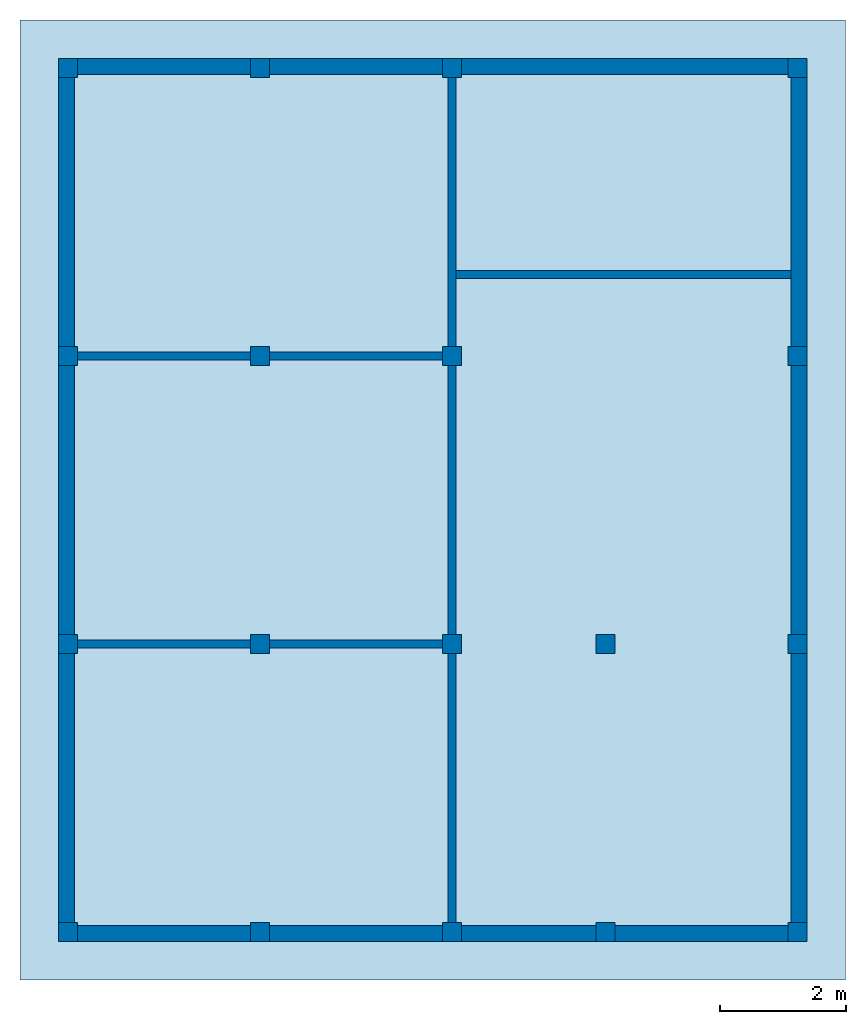
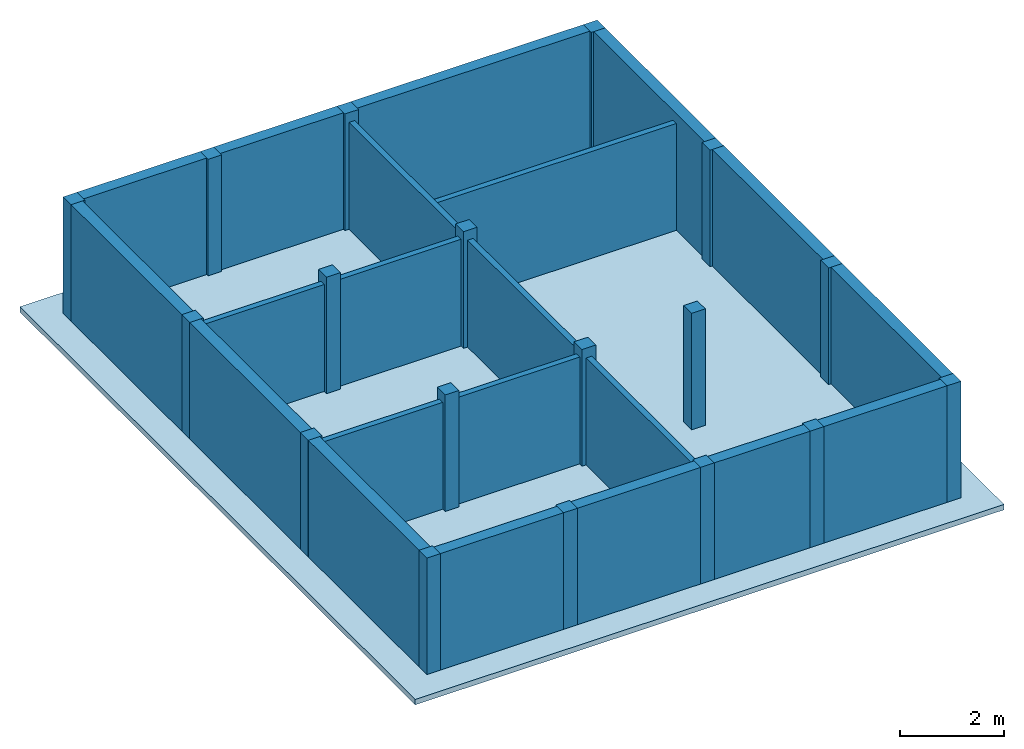
# One storey: 18 columns, 10 walls, 1 slab.
"""IFC2X3 building model written with IfcOpenShell, lengths in feet."""

from ifc_helpers import new_model, entity, si_unit, converted_unit, derived_unit, direction, frame, frame_2d, origin, origin_2d_with_axis, place, context, subcontext, project, spatial, rectangle, extrude, source, transform, mapped, material, layer, layer_set, layer_usage, type_object, type_shapes, element, save


model = new_model("IFC2X3")

# Units and contexts
model_context = context("Model", 3, precision=0.0001, world=origin(), true_north=direction((6.123031769111886e-17, 1.0)))
body_context = subcontext(model_context, "Body", "Model", "MODEL_VIEW")
ifc_project = project(units=[converted_unit("LENGTHUNIT", "FOOT", entity("IfcLengthMeasure", 0.3048), si_unit("LENGTHUNIT", "METRE"), dimensions=[1, 0, 0, 0, 0, 0, 0]), converted_unit("AREAUNIT", "SQUARE FOOT", entity("IfcAreaMeasure", 0.09290304), si_unit("AREAUNIT", "SQUARE_METRE"), dimensions=[2, 0, 0, 0, 0, 0, 0]), converted_unit("VOLUMEUNIT", "CUBIC FOOT", entity("IfcVolumeMeasure", 0.028316846592000004), si_unit("VOLUMEUNIT", "CUBIC_METRE"), dimensions=[3, 0, 0, 0, 0, 0, 0]), converted_unit("PLANEANGLEUNIT", "DEGREE", entity("IfcPlaneAngleMeasure", 0.017453292519943278), si_unit("PLANEANGLEUNIT", "RADIAN"), dimensions=[0, 0, 0, 0, 0, 0, 0]), si_unit("MASSUNIT", "GRAM", prefix="KILO"), derived_unit("MASSDENSITYUNIT", [(si_unit("MASSUNIT", "GRAM", prefix="KILO"), 1), (si_unit("LENGTHUNIT", "METRE"), -3)]), derived_unit("IONCONCENTRATIONUNIT", [(si_unit("MASSUNIT", "GRAM", prefix="KILO"), 1), (si_unit("LENGTHUNIT", "METRE"), -3)]), derived_unit("MOMENTOFINERTIAUNIT", [(si_unit("LENGTHUNIT", "METRE"), 4)]), si_unit("TIMEUNIT", "SECOND"), si_unit("FREQUENCYUNIT", "HERTZ"), si_unit("THERMODYNAMICTEMPERATUREUNIT", "DEGREE_CELSIUS"), derived_unit("THERMALTRANSMITTANCEUNIT", [(si_unit("MASSUNIT", "GRAM", prefix="KILO"), 1), (si_unit("THERMODYNAMICTEMPERATUREUNIT", "KELVIN"), -1), (si_unit("TIMEUNIT", "SECOND"), -3)]), derived_unit("THERMALCONDUCTANCEUNIT", [(si_unit("MASSUNIT", "GRAM", prefix="KILO"), 1), (si_unit("THERMODYNAMICTEMPERATUREUNIT", "KELVIN"), -1), (si_unit("TIMEUNIT", "SECOND"), -3), (si_unit("LENGTHUNIT", "METRE"), 1)]), derived_unit("VOLUMETRICFLOWRATEUNIT", [(si_unit("LENGTHUNIT", "METRE"), 3), (si_unit("TIMEUNIT", "SECOND"), -1)]), derived_unit("MASSFLOWRATEUNIT", [(si_unit("MASSUNIT", "GRAM", prefix="KILO"), 1), (si_unit("TIMEUNIT", "SECOND"), -1)]), derived_unit("ROTATIONALFREQUENCYUNIT", [(si_unit("TIMEUNIT", "SECOND"), -1)]), si_unit("ELECTRICCURRENTUNIT", "AMPERE"), si_unit("ELECTRICVOLTAGEUNIT", "VOLT"), si_unit("POWERUNIT", "WATT"), converted_unit("FORCEUNIT", "KIP", entity("IfcForceMeasure", 2.088543423315013e-05), si_unit("FORCEUNIT", "NEWTON"), dimensions=[1, 1, -2, 0, 0, 0, 0]), si_unit("ILLUMINANCEUNIT", "LUX"), si_unit("LUMINOUSFLUXUNIT", "LUMEN"), si_unit("LUMINOUSINTENSITYUNIT", "CANDELA"), si_unit("ENERGYUNIT", "JOULE"), derived_unit("USERDEFINED", [(si_unit("MASSUNIT", "GRAM", prefix="KILO"), -1), (si_unit("LENGTHUNIT", "METRE"), -2), (si_unit("TIMEUNIT", "SECOND"), 3), (si_unit("LUMINOUSFLUXUNIT", "LUMEN"), 1)]), derived_unit("USERDEFINED", [(si_unit("MASSUNIT", "GRAM", prefix="KILO"), 1), (si_unit("TIMEUNIT", "SECOND"), -3), (si_unit("LENGTHUNIT", "METRE"), 3), (si_unit("ELECTRICCURRENTUNIT", "AMPERE"), -2)]), derived_unit("SOUNDPOWERUNIT", [(si_unit("MASSUNIT", "GRAM", prefix="KILO"), 1), (si_unit("TIMEUNIT", "SECOND"), -3), (si_unit("LENGTHUNIT", "METRE"), 2)]), derived_unit("SOUNDPRESSUREUNIT", [(si_unit("MASSUNIT", "GRAM", prefix="KILO"), 1), (si_unit("LENGTHUNIT", "METRE"), -1), (si_unit("TIMEUNIT", "SECOND"), -2)]), derived_unit("LINEARVELOCITYUNIT", [(si_unit("LENGTHUNIT", "METRE"), 1), (si_unit("TIMEUNIT", "SECOND"), -1)]), si_unit("PRESSUREUNIT", "PASCAL"), derived_unit("USERDEFINED", [(si_unit("MASSUNIT", "GRAM", prefix="KILO"), 1), (si_unit("LENGTHUNIT", "METRE"), -2), (si_unit("TIMEUNIT", "SECOND"), -2)]), derived_unit("LINEARFORCEUNIT", [(si_unit("MASSUNIT", "GRAM", prefix="KILO"), 1), (si_unit("TIMEUNIT", "SECOND"), -2)]), derived_unit("PLANARFORCEUNIT", [(si_unit("MASSUNIT", "GRAM", prefix="KILO"), 1), (si_unit("LENGTHUNIT", "METRE"), -1), (si_unit("TIMEUNIT", "SECOND"), -2)]), derived_unit("SPECIFICHEATCAPACITYUNIT", [(si_unit("THERMODYNAMICTEMPERATUREUNIT", "KELVIN"), -1), (si_unit("LENGTHUNIT", "METRE"), 2), (si_unit("TIMEUNIT", "SECOND"), -2)]), derived_unit("HEATFLUXDENSITYUNIT", [(si_unit("MASSUNIT", "GRAM", prefix="KILO"), 1), (si_unit("TIMEUNIT", "SECOND"), -3)]), derived_unit("HEATINGVALUEUNIT", [(si_unit("LENGTHUNIT", "METRE"), 2), (si_unit("TIMEUNIT", "SECOND"), -2)]), derived_unit("VAPORPERMEABILITYUNIT", [(si_unit("LENGTHUNIT", "METRE"), -1), (si_unit("TIMEUNIT", "SECOND"), 1)]), derived_unit("DYNAMICVISCOSITYUNIT", [(si_unit("MASSUNIT", "GRAM", prefix="KILO"), 1), (si_unit("TIMEUNIT", "SECOND"), -1), (si_unit("LENGTHUNIT", "METRE"), -1)]), derived_unit("THERMALEXPANSIONCOEFFICIENTUNIT", [(si_unit("THERMODYNAMICTEMPERATUREUNIT", "KELVIN"), -1)]), derived_unit("MODULUSOFELASTICITYUNIT", [(si_unit("MASSUNIT", "GRAM", prefix="KILO"), 1), (si_unit("LENGTHUNIT", "METRE"), -1), (si_unit("TIMEUNIT", "SECOND"), -2)]), derived_unit("ISOTHERMALMOISTURECAPACITYUNIT", [(si_unit("LENGTHUNIT", "METRE"), 3), (si_unit("MASSUNIT", "GRAM", prefix="KILO"), -1)]), derived_unit("MOISTUREDIFFUSIVITYUNIT", [(si_unit("TIMEUNIT", "SECOND"), -1), (si_unit("LENGTHUNIT", "METRE"), 2)]), derived_unit("MASSPERLENGTHUNIT", [(si_unit("MASSUNIT", "GRAM", prefix="KILO"), 1), (si_unit("LENGTHUNIT", "METRE"), -1)]), derived_unit("THERMALRESISTANCEUNIT", [(si_unit("MASSUNIT", "GRAM", prefix="KILO"), -1), (si_unit("TIMEUNIT", "SECOND"), 3), (si_unit("THERMODYNAMICTEMPERATUREUNIT", "KELVIN"), 1)]), derived_unit("ACCELERATIONUNIT", [(si_unit("LENGTHUNIT", "METRE"), 1), (si_unit("TIMEUNIT", "SECOND"), -2)]), derived_unit("ANGULARVELOCITYUNIT", [(si_unit("TIMEUNIT", "SECOND"), -1), (si_unit("PLANEANGLEUNIT", "RADIAN"), 1)]), derived_unit("LINEARSTIFFNESSUNIT", [(si_unit("MASSUNIT", "GRAM", prefix="KILO"), 1), (si_unit("TIMEUNIT", "SECOND"), -2)]), derived_unit("WARPINGCONSTANTUNIT", [(si_unit("LENGTHUNIT", "METRE"), 6)]), derived_unit("LINEARMOMENTUNIT", [(si_unit("MASSUNIT", "GRAM", prefix="KILO"), 1), (si_unit("LENGTHUNIT", "METRE"), 1), (si_unit("TIMEUNIT", "SECOND"), -2)]), derived_unit("TORQUEUNIT", [(si_unit("MASSUNIT", "GRAM", prefix="KILO"), 1), (si_unit("LENGTHUNIT", "METRE"), 2), (si_unit("TIMEUNIT", "SECOND"), -2)])], contexts=[model_context])

# Site, building, storey
site_placement = place(None, origin())
site = spatial("IfcSite", under=ifc_project, at=site_placement, CompositionType="ELEMENT")
building_placement = place(site_placement, origin())
building = spatial("IfcBuilding", under=site, at=building_placement, CompositionType="ELEMENT")
storey_placement = place(building_placement, frame((0.0, 0.0, 18.833333333333574)))
storey = spatial("IfcBuildingStorey", under=building, at=storey_placement, Name="Second Floor", CompositionType="ELEMENT", Elevation=18.833333333333574)

# Columns
ifc_material_1 = material(Name="Concrete, Cast-in-Place gray")
column_type = type_object("IfcColumnType", PredefinedType="COLUMN", material=ifc_material_1)
shared_shape = source(origin(), body_context, "Body", "SweptSolid", [
    extrude(rectangle(XDim=0.9999999999999999, YDim=0.9999999999999999, at=origin_2d_with_axis()), frame((0.0, 0.0, 18.833333333333574), z_axis=(0.0, 0.0, 1.0), x_axis=(-1.0, 0.0, 0.0)), (0.0, 0.0, 1.0), 9.00000000000162),
])
type_shapes(column_type, [shared_shape])
for number, where in (
    (1, (9.874478019162162, -49.84124484724893, -18.833333333333574)),
    (2, (29.874478019162154, -49.841244847248994, -18.833333333333574)),
    (3, (37.87447801916216, -49.84124484724902, -18.833333333333574)),
    (4, (47.87447801916217, -49.84124484724906, -18.833333333333574)),
    (5, (19.874478019162158, -49.841244847248966, -18.833333333333574)),
    (6, (9.874478019162186, -34.84124484724893, -18.833333333333574)),
    (7, (29.87447801916219, -34.841244847248994, -18.833333333333574)),
    (8, (37.87447801916219, -34.84124484724902, -18.833333333333574)),
    (9, (47.87447801916219, -34.84124484724906, -18.833333333333574)),
    (10, (19.874478019162183, -34.841244847248966, -18.833333333333574)),
    (11, (9.874478019162211, -19.841244847248934, -18.833333333333574)),
    (12, (29.87447801916221, -19.841244847248998, -18.833333333333574)),
    (13, (47.87447801916221, -19.841244847249058, -18.833333333333574)),
    (14, (19.874478019162204, -19.841244847248966, -18.833333333333574)),
    (15, (9.874478019162234, -4.841244847248884, -18.833333333333574)),
    (16, (29.874478019162233, -4.841244847248948, -18.833333333333574)),
    (17, (47.87447801916224, -4.841244847249006, -18.833333333333574)),
    (18, (19.87447801916223, -4.841244847248915, -18.833333333333574)),
):
    element("IfcColumn", number, at=place(storey_placement, frame(where)), inside=storey, type_object=column_type, material=ifc_material_1, context=body_context, shape_type="MappedRepresentation", body=[
        mapped(shared_shape, transform((0.0, 0.0, 0.0), scale=1.0)),
    ])

# Slab
ifc_material_2 = material(Name="Default Floor")
ifc_layer_1 = layer(ifc_material_2, 0.4166666666666667)
ifc_layer_set_1 = layer_set([ifc_layer_1])
ifc_layer_usage_1 = layer_usage(ifc_layer_set_1, "AXIS3", "POSITIVE", 0.0)
slab_type = type_object("IfcSlabType", PredefinedType="FLOOR", material=ifc_layer_set_1)
slab_placement = place(storey_placement, origin())
element("IfcSlab", 19, at=slab_placement, inside=storey, type_object=slab_type, material=ifc_layer_usage_1, PredefinedType="FLOOR", context=body_context, shape_type="SweptSolid", body=[
    extrude(rectangle(XDim=50.00000000000018, YDim=42.99999999999993, at=origin_2d_with_axis()), frame((28.874478019162204, -27.34124484724897, 0.0), z_axis=(0.0, 0.0, -1.0), x_axis=(0.0, 1.0, 0.0)), (0.0, 0.0, 1.0), 0.41666666666666785),
])

# Walls
ifc_material_3 = material(Name="Default Wall")
ifc_layer_2 = layer(ifc_material_3, 0.041666666666666664)
ifc_layer_3 = layer(ifc_material_3, 0.75)
ifc_layer_4 = layer(ifc_material_3, 0.041666666666666664)
ifc_layer_set_2 = layer_set([ifc_layer_2, ifc_layer_3, ifc_layer_4])
ifc_layer_usage_2 = layer_usage(ifc_layer_set_2, "AXIS2", "NEGATIVE", 0.4166666666666667)
wall_type_1 = type_object("IfcWallType", PredefinedType="STANDARD", material=ifc_layer_set_2)
wall_1_placement = place(storey_placement, frame((9.374478019162236, -4.757911513915549, 0.0)))
element("IfcWallStandardCase", 20, at=wall_1_placement, inside=storey, type_object=wall_type_1, material=ifc_layer_usage_2, context=body_context, shape_type="SweptSolid", body=[
    extrude(rectangle(XDim=38.1666666666666, YDim=0.8333333333333339, at=frame_2d((19.0833333333333, 0.0), x_axis=(-1.0, 0.0))), origin(), (0.0, 0.0, 1.0), 9.00000000000162),
])
wall_2_placement = place(storey_placement, frame((9.791144685828902, -50.34124484724887, 0.0), z_axis=(0.0, 0.0, 1.0), x_axis=(0.0, 1.0, 0.0)))
element("IfcWallStandardCase", 21, at=wall_2_placement, inside=storey, type_object=wall_type_1, material=ifc_layer_usage_2, context=body_context, shape_type="SweptSolid", body=[
    extrude(rectangle(XDim=45.16666666666666, YDim=0.8333333333333321, at=frame_2d((22.58333333333333, 0.0), x_axis=(-1.0, 0.0))), origin(), (0.0, 0.0, 1.0), 9.00000000000162),
])
wall_3_placement = place(storey_placement, frame((48.37447801916217, -49.924578180582216, 0.0), z_axis=(0.0, 0.0, 1.0), x_axis=(-1.0, 0.0, 0.0)))
element("IfcWallStandardCase", 22, at=wall_3_placement, inside=storey, type_object=wall_type_1, material=ifc_layer_usage_2, context=body_context, shape_type="SweptSolid", body=[
    extrude(rectangle(XDim=38.1666666666666, YDim=0.8333333333333286, at=frame_2d((19.0833333333333, 0.0), x_axis=(-1.0, 0.0))), origin(), (0.0, 0.0, 1.0), 9.00000000000162),
])
wall_4_placement = place(storey_placement, frame((47.957811352495504, -4.3412448472488805, 0.0), z_axis=(0.0, 0.0, 1.0), x_axis=(0.0, -1.0, 0.0)))
element("IfcWallStandardCase", 23, at=wall_4_placement, inside=storey, type_object=wall_type_1, material=ifc_layer_usage_2, context=body_context, shape_type="SweptSolid", body=[
    extrude(rectangle(XDim=45.166666666666664, YDim=0.8333333333333286, at=frame_2d((22.583333333333332, 0.0), x_axis=(-1.0, 0.0))), origin(), (0.0, 0.0, 1.0), 9.00000000000162),
])
ifc_layer_5 = layer(ifc_material_3, 0.4166666666666667)
ifc_layer_set_3 = layer_set([ifc_layer_5])
ifc_layer_usage_3 = layer_usage(ifc_layer_set_3, "AXIS2", "NEGATIVE", 0.20833333333333334)
wall_type_2 = type_object("IfcWallType", PredefinedType="STANDARD", material=ifc_layer_set_3)
wall_5_placement = place(storey_placement, frame((10.37447801916221, -19.841244847248937, 0.0)))
element("IfcWallStandardCase", 24, at=wall_5_placement, inside=storey, type_object=wall_type_2, material=ifc_layer_usage_3, context=body_context, shape_type="SweptSolid", body=[
    extrude(rectangle(XDim=19.0, YDim=0.4166666666666643, at=frame_2d((9.5, 0.0), x_axis=(-1.0, 0.0))), origin(), (0.0, 0.0, 1.0), 8.249999999998622),
])
wall_6_placement = place(storey_placement, frame((29.87447801916221, -19.341244847248994, 0.0), z_axis=(0.0, 0.0, 1.0), x_axis=(0.0, 1.0, 0.0)))
element("IfcWallStandardCase", 25, at=wall_6_placement, inside=storey, type_object=wall_type_2, material=ifc_layer_usage_3, context=body_context, shape_type="SweptSolid", body=[
    extrude(rectangle(XDim=14.000000000000046, YDim=0.4166666666666643, at=frame_2d((7.000000000000023, 0.0), x_axis=(-1.0, 0.0))), origin(), (0.0, 0.0, 1.0), 8.249999999998622),
])
wall_7_placement = place(storey_placement, frame((29.87447801916221, -20.341244847249, 0.0), z_axis=(0.0, 0.0, 1.0), x_axis=(0.0, -1.0, 0.0)))
element("IfcWallStandardCase", 26, at=wall_7_placement, inside=storey, type_object=wall_type_2, material=ifc_layer_usage_3, context=body_context, shape_type="SweptSolid", body=[
    extrude(rectangle(XDim=13.999999999999986, YDim=0.4166666666666643, at=frame_2d((6.999999999999993, 0.0), x_axis=(-1.0, 0.0))), origin(), (0.0, 0.0, 1.0), 8.249999999998622),
])
wall_8_placement = place(storey_placement, frame((29.37447801916219, -34.841244847248994, 0.0), z_axis=(0.0, 0.0, 1.0), x_axis=(-1.0, 0.0, 0.0)))
element("IfcWallStandardCase", 27, at=wall_8_placement, inside=storey, type_object=wall_type_2, material=ifc_layer_usage_3, context=body_context, shape_type="SweptSolid", body=[
    extrude(rectangle(XDim=19.000000000000007, YDim=0.4166666666666714, at=frame_2d((9.500000000000004, 0.0), x_axis=(-1.0, 0.0))), origin(), (0.0, 0.0, 1.0), 8.249999999998622),
])
wall_9_placement = place(storey_placement, frame((29.87447801916219, -35.341244847249, 0.0), z_axis=(0.0, 0.0, 1.0), x_axis=(0.0, -1.0, 0.0)))
element("IfcWallStandardCase", 28, at=wall_9_placement, inside=storey, type_object=wall_type_2, material=ifc_layer_usage_3, context=body_context, shape_type="SweptSolid", body=[
    extrude(rectangle(XDim=13.999999999999986, YDim=0.4166666666666643, at=frame_2d((6.999999999999993, 0.0), x_axis=(-1.0, 0.0))), origin(), (0.0, 0.0, 1.0), 8.249999999998622),
])
wall_10_placement = place(storey_placement, frame((30.082811352495554, -15.591244847248992, 0.0)))
element("IfcWallStandardCase", 29, at=wall_10_placement, inside=storey, type_object=wall_type_2, material=ifc_layer_usage_3, context=body_context, shape_type="SweptSolid", body=[
    extrude(rectangle(XDim=17.45833333333328, YDim=0.41666666666666785, at=frame_2d((8.72916666666664, -1.3877787807814457e-16), x_axis=(-1.0, 0.0))), origin(), (0.0, 0.0, 1.0), 8.249999999998622),
])

save(model, "model.ifc")
